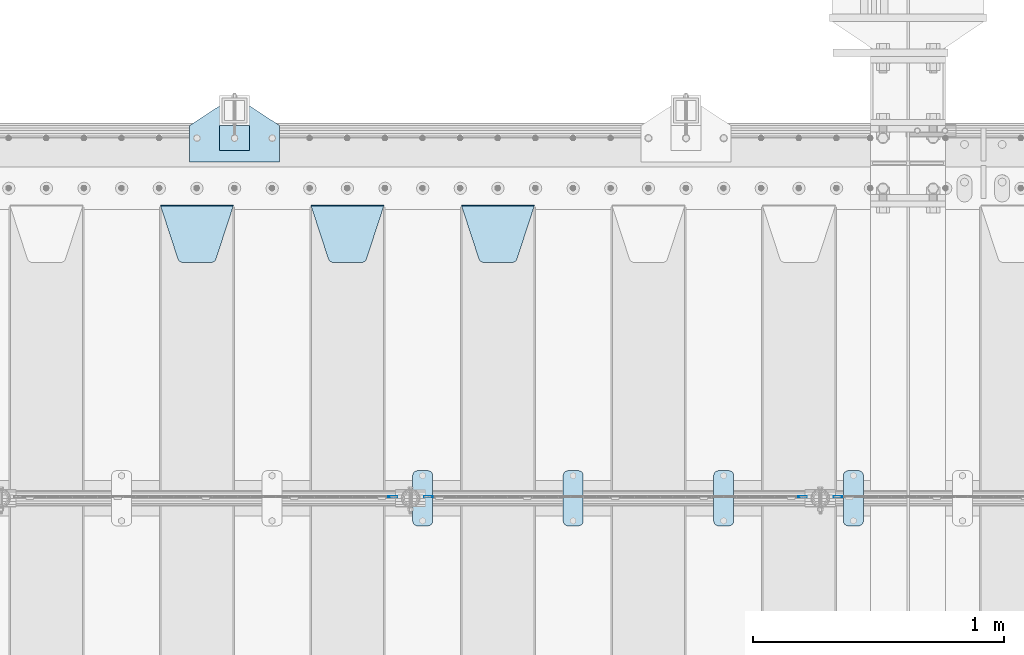
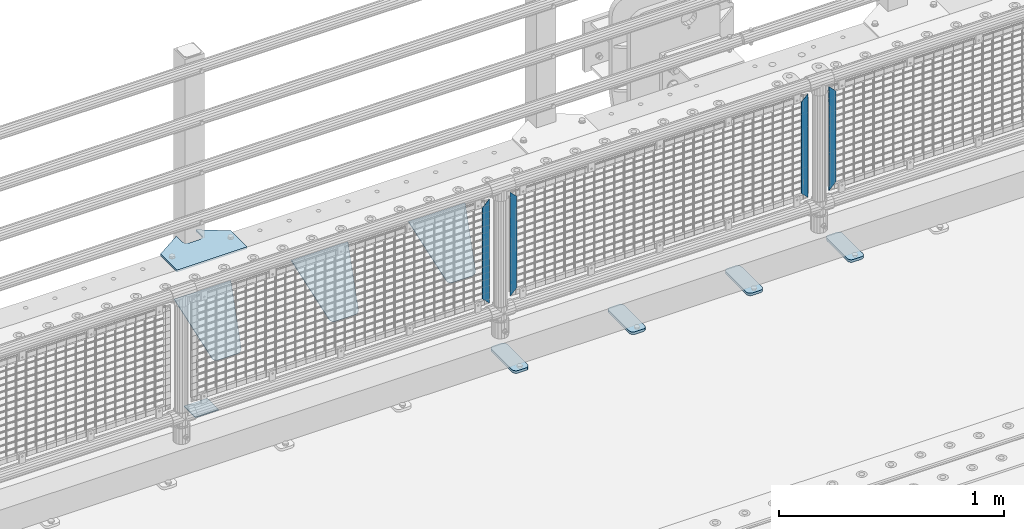
# One storey, part 237 of 270: 13 plates.
"""IFC2X3 building model written with IfcOpenShell, lengths in millimetres."""

from ifc_helpers import new_model, si_unit, frame, origin_with_axes, place, context, subcontext, project, spatial, faceted_brep, material, type_object, element, save


model = new_model("IFC2X3")

# Units and contexts
model_context = context("Model", 3, precision=1e-05, world=origin_with_axes())
body_context = subcontext(model_context, "Body", "Model", "MODEL_VIEW")
ifc_project = project(units=[si_unit("LENGTHUNIT", "METRE", prefix="MILLI"), si_unit("AREAUNIT", "SQUARE_METRE"), si_unit("VOLUMEUNIT", "CUBIC_METRE"), si_unit("MASSUNIT", "GRAM", prefix="KILO"), si_unit("TIMEUNIT", "SECOND"), si_unit("PLANEANGLEUNIT", "RADIAN"), si_unit("SOLIDANGLEUNIT", "STERADIAN"), si_unit("THERMODYNAMICTEMPERATUREUNIT", "DEGREE_CELSIUS"), si_unit("LUMINOUSINTENSITYUNIT", "LUMEN")], contexts=[model_context])

# Site, building, storey
site_placement = place(None, origin_with_axes())
site = spatial("IfcSite", under=ifc_project, at=site_placement, CompositionType="ELEMENT")
building_placement = place(site_placement, origin_with_axes())
building = spatial("IfcBuilding", under=site, at=building_placement, Name="Standard", CompositionType="ELEMENT")
storey_placement = place(building_placement, origin_with_axes())
storey = spatial("IfcBuildingStorey", under=building, at=storey_placement, Name="Undefined", CompositionType="ELEMENT", Elevation=0.0)

# Plates
ifc_material_1 = material(Name="STEEL/S355J2")
plate_type_1 = type_object("IfcPlateType", PredefinedType="NOTDEFINED")
plate_1_placement = place(storey_placement, frame((11170.0, -14995.0, 5.00000000004911), z_axis=(0.0, 1.0, 0.0), x_axis=(1.0, 0.0, 0.0)))
element("IfcPlate", 1, at=plate_1_placement, inside=storey, type_object=plate_type_1, material=ifc_material_1, context=body_context, shape_type="Brep", body=[
    faceted_brep([(0.0, -5.0, 0.0), (2.31396552408114e-06, -5.0, 145.0), (2.31396552408114e-06, 5.0, 145.0), (0.0, 5.0, 0.0), (130.0, -5.0, 230.0), (130.0, 5.0, 230.0), (130.0, -5.0, 180.0), (130.0, 5.0, 180.0), (130.48036798992, -5.0, 175.122741949597), (130.48036798992, 5.0, 175.122741949597), (131.903011687216, -5.0, 170.432914190873), (131.903011687216, 5.0, 170.432914190873), (134.213259692435, -5.0, 166.11074417451), (134.213259692435, 5.0, 166.11074417451), (137.322330470335, -5.0, 162.322330470337), (137.322330470335, 5.0, 162.322330470337), (141.110744174512, -5.0, 159.213259692437), (141.110744174512, 5.0, 159.213259692437), (145.432914190871, -5.0, 156.903011687218), (145.432914190871, 5.0, 156.903011687218), (150.122741949595, -5.0, 155.48036798992), (150.122741949595, 5.0, 155.48036798992), (155.0, -5.0, 155.0), (155.0, 5.0, 155.0), (205.0, -5.0, 155.0), (205.0, 5.0, 155.0), (209.877258050405, -5.0, 155.48036798992), (209.877258050405, 5.0, 155.48036798992), (214.567085809129, -5.0, 156.903011687218), (214.567085809129, 5.0, 156.903011687218), (218.889255825488, -5.0, 159.213259692437), (218.889255825488, 5.0, 159.213259692437), (222.677669529665, -5.0, 162.322330470337), (222.677669529665, 5.0, 162.322330470337), (225.786740307565, -5.0, 166.11074417451), (225.786740307565, 5.0, 166.11074417451), (228.096988312784, -5.0, 170.432914190873), (228.096988312784, 5.0, 170.432914190873), (229.51963201008, -5.0, 175.122741949597), (229.51963201008, 5.0, 175.122741949597), (230.0, -5.0, 180.0), (230.0, 5.0, 180.0), (230.0, -5.0, 230.0), (230.0, 5.0, 230.0), (360.0, -5.0, 145.0), (360.0, 5.0, 145.0), (360.0, -5.0, -7.27595761418343e-12), (360.0, 5.0, -7.27595761418343e-12)], [[[0, 1, 2, 3]], [[1, 4, 5, 2]], [[4, 6, 7, 5]], [[6, 8, 9, 7]], [[8, 10, 11, 9]], [[10, 12, 13, 11]], [[12, 14, 15, 13]], [[14, 16, 17, 15]], [[16, 18, 19, 17]], [[18, 20, 21, 19]], [[20, 22, 23, 21]], [[22, 24, 25, 23]], [[24, 26, 27, 25]], [[26, 28, 29, 27]], [[28, 30, 31, 29]], [[30, 32, 33, 31]], [[32, 34, 35, 33]], [[34, 36, 37, 35]], [[36, 38, 39, 37]], [[38, 40, 41, 39]], [[40, 42, 43, 41]], [[42, 44, 45, 43]], [[44, 46, 47, 45]], [[46, 0, 3, 47]], [[5, 7, 9, 11, 13, 15, 17, 19, 21, 23, 25, 27, 29, 31, 33, 35, 37, 39, 41, 43, 45, 47, 3, 2]], [[46, 44, 42, 40, 38, 36, 34, 32, 30, 28, 26, 24, 22, 20, 18, 16, 14, 12, 10, 8, 6, 4, 1, 0]]]),
])
plate_type_2 = type_object("IfcPlateType", PredefinedType="NOTDEFINED")
plate_2_placement = place(storey_placement, frame((11290.0000000001, -14949.9999999998, -857.500000000002), z_axis=(0.0, 1.0, 0.0), x_axis=(1.0, 0.0, 0.0)))
element("IfcPlate", 2, at=plate_2_placement, inside=storey, type_object=plate_type_2, material=ifc_material_1, context=body_context, shape_type="Brep", body=[
    faceted_brep([(0.0, -2.5, 0.0), (0.0, -2.5, 100.0), (0.0, 2.5, 100.0), (0.0, 2.5, 0.0), (120.0, -2.5, 100.0), (120.0, 2.5, 100.0), (120.0, -2.5, 0.0), (120.0, 2.5, 0.0)], [[[0, 1, 2, 3]], [[1, 4, 5, 2]], [[4, 6, 7, 5]], [[6, 0, 3, 7]], [[5, 7, 3, 2]], [[6, 4, 1, 0]]]),
])
plate_type_3 = type_object("IfcPlateType", PredefinedType="NOTDEFINED")
plate_3_placement = place(storey_placement, frame((13777.0, -16225.5, 21.0199999999977), z_axis=(1.0, 0.0, 0.0), x_axis=(0.0, -1.0, 0.0)))
element("IfcPlate", 3, at=plate_3_placement, inside=storey, type_object=plate_type_3, material=ifc_material_1, context=body_context, shape_type="Brep", body=[
    faceted_brep([(0.0, -7.0, 20.0), (0.0, -7.0, 60.0), (0.0, 7.0, 60.0), (0.0, 7.0, 20.0), (0.384294391937146, -7.0, 63.9018064403208), (0.384294391937146, 7.0, 63.9018064403208), (1.52240934977453, -7.0, 67.6536686473009), (1.52240934977453, 7.0, 67.6536686473009), (3.37060775395003, -7.0, 71.1114046603907), (3.37060775395003, 7.0, 71.1114046603907), (5.8578643762703, -7.0, 74.1421356237297), (5.8578643762703, 7.0, 74.1421356237297), (8.88859533960931, -7.0, 76.62939224605), (8.88859533960931, 7.0, 76.62939224605), (12.3463313526991, -7.0, 78.4775906502255), (12.3463313526991, 7.0, 78.4775906502255), (16.0981935596792, -7.0, 79.6157056080629), (16.0981935596792, 7.0, 79.6157056080629), (20.0, -7.0, 80.0), (20.0, 7.0, 80.0), (200.0, -7.0, 80.0), (200.0, 7.0, 80.0), (203.901806440321, -7.0, 79.6157056080629), (203.901806440321, 7.0, 79.6157056080629), (207.653668647301, -7.0, 78.4775906502255), (207.653668647301, 7.0, 78.4775906502255), (211.111404660391, -7.0, 76.62939224605), (211.111404660391, 7.0, 76.62939224605), (214.142135623733, -7.0, 74.1421356237297), (214.142135623733, 7.0, 74.1421356237297), (216.629392246054, -7.0, 71.1114046603907), (216.629392246054, 7.0, 71.1114046603907), (218.477590650225, -7.0, 67.6536686473009), (218.477590650225, 7.0, 67.6536686473009), (219.615705608063, -7.0, 63.9018064403208), (219.615705608063, 7.0, 63.9018064403208), (220.0, -7.0, 60.0), (220.0, 7.0, 60.0), (220.0, -7.0, 20.0), (220.0, 7.0, 20.0), (219.615705608063, -7.0, 16.0981935596792), (219.615705608063, 7.0, 16.0981935596792), (218.477590650225, -7.0, 12.3463313526991), (218.477590650225, 7.0, 12.3463313526991), (216.629392246054, -7.0, 8.88859533960931), (216.629392246054, 7.0, 8.88859533960931), (214.142135623733, -7.0, 5.8578643762703), (214.142135623733, 7.0, 5.8578643762703), (211.111404660391, -7.0, 3.37060775395003), (211.111404660391, 7.0, 3.37060775395003), (207.653668647301, -7.0, 1.52240934977453), (207.653668647301, 7.0, 1.52240934977453), (203.901806440321, -7.0, 0.384294391937146), (203.901806440321, 7.0, 0.384294391937146), (200.0, -7.0, 0.0), (200.0, 7.0, 0.0), (20.0, -7.0, 0.0), (20.0, 7.0, 0.0), (16.0981935596792, -7.0, 0.384294391937146), (16.0981935596792, 7.0, 0.384294391937146), (12.3463313526991, -7.0, 1.52240934977453), (12.3463313526991, 7.0, 1.52240934977453), (8.88859533960931, -7.0, 3.37060775395003), (8.88859533960931, 7.0, 3.37060775395003), (5.8578643762703, -7.0, 5.8578643762703), (5.8578643762703, 7.0, 5.8578643762703), (3.37060775395003, -7.0, 8.88859533960931), (3.37060775395003, 7.0, 8.88859533960931), (1.52240934977453, -7.0, 12.3463313526991), (1.52240934977453, 7.0, 12.3463313526991), (0.384294391937146, -7.0, 16.0981935596792), (0.384294391937146, 7.0, 16.0981935596792)], [[[0, 1, 2, 3]], [[1, 4, 5, 2]], [[4, 6, 7, 5]], [[6, 8, 9, 7]], [[8, 10, 11, 9]], [[10, 12, 13, 11]], [[12, 14, 15, 13]], [[14, 16, 17, 15]], [[16, 18, 19, 17]], [[18, 20, 21, 19]], [[20, 22, 23, 21]], [[22, 24, 25, 23]], [[24, 26, 27, 25]], [[26, 28, 29, 27]], [[28, 30, 31, 29]], [[30, 32, 33, 31]], [[32, 34, 35, 33]], [[34, 36, 37, 35]], [[36, 38, 39, 37]], [[38, 40, 41, 39]], [[40, 42, 43, 41]], [[42, 44, 45, 43]], [[44, 46, 47, 45]], [[46, 48, 49, 47]], [[48, 50, 51, 49]], [[50, 52, 53, 51]], [[52, 54, 55, 53]], [[54, 56, 57, 55]], [[56, 58, 59, 57]], [[58, 60, 61, 59]], [[60, 62, 63, 61]], [[62, 64, 65, 63]], [[64, 66, 67, 65]], [[66, 68, 69, 67]], [[68, 70, 71, 69]], [[70, 0, 3, 71]], [[5, 7, 9, 11, 13, 15, 17, 19, 21, 23, 25, 27, 29, 31, 33, 35, 37, 39, 41, 43, 45, 47, 49, 51, 53, 55, 57, 59, 61, 63, 65, 67, 69, 71, 3, 2]], [[70, 68, 66, 64, 62, 60, 58, 56, 54, 52, 50, 48, 46, 44, 42, 40, 38, 36, 34, 32, 30, 28, 26, 24, 22, 20, 18, 16, 14, 12, 10, 8, 6, 4, 1, 0]]]),
])
plate_4_placement = place(storey_placement, frame((13260.0, -16225.5, 21.0199999999977), z_axis=(1.0, 0.0, 0.0), x_axis=(0.0, -1.0, 0.0)))
element("IfcPlate", 4, at=plate_4_placement, inside=storey, type_object=plate_type_3, material=ifc_material_1, context=body_context, shape_type="Brep", body=[
    faceted_brep([(0.0, -7.0, 20.0), (0.0, -7.0, 60.0), (0.0, 7.0, 60.0), (0.0, 7.0, 20.0), (0.384294391937146, -7.0, 63.9018064403208), (0.384294391937146, 7.0, 63.9018064403208), (1.52240934977453, -7.0, 67.6536686473009), (1.52240934977453, 7.0, 67.6536686473009), (3.37060775395003, -7.0, 71.1114046603907), (3.37060775395003, 7.0, 71.1114046603907), (5.8578643762703, -7.0, 74.1421356237297), (5.8578643762703, 7.0, 74.1421356237297), (8.88859533960931, -7.0, 76.62939224605), (8.88859533960931, 7.0, 76.62939224605), (12.3463313526991, -7.0, 78.4775906502255), (12.3463313526991, 7.0, 78.4775906502255), (16.0981935596792, -7.0, 79.6157056080629), (16.0981935596792, 7.0, 79.6157056080629), (20.0, -7.0, 80.0), (20.0, 7.0, 80.0), (200.0, -7.0, 80.0), (200.0, 7.0, 80.0), (203.901806440321, -7.0, 79.6157056080629), (203.901806440321, 7.0, 79.6157056080629), (207.653668647301, -7.0, 78.4775906502255), (207.653668647301, 7.0, 78.4775906502255), (211.111404660391, -7.0, 76.62939224605), (211.111404660391, 7.0, 76.62939224605), (214.142135623733, -7.0, 74.1421356237297), (214.142135623733, 7.0, 74.1421356237297), (216.629392246054, -7.0, 71.1114046603907), (216.629392246054, 7.0, 71.1114046603907), (218.477590650225, -7.0, 67.6536686473009), (218.477590650225, 7.0, 67.6536686473009), (219.615705608063, -7.0, 63.9018064403208), (219.615705608063, 7.0, 63.9018064403208), (220.0, -7.0, 60.0), (220.0, 7.0, 60.0), (220.0, -7.0, 20.0), (220.0, 7.0, 20.0), (219.615705608063, -7.0, 16.0981935596792), (219.615705608063, 7.0, 16.0981935596792), (218.477590650225, -7.0, 12.3463313526991), (218.477590650225, 7.0, 12.3463313526991), (216.629392246054, -7.0, 8.88859533960931), (216.629392246054, 7.0, 8.88859533960931), (214.142135623733, -7.0, 5.8578643762703), (214.142135623733, 7.0, 5.8578643762703), (211.111404660391, -7.0, 3.37060775395003), (211.111404660391, 7.0, 3.37060775395003), (207.653668647301, -7.0, 1.52240934977453), (207.653668647301, 7.0, 1.52240934977453), (203.901806440321, -7.0, 0.384294391937146), (203.901806440321, 7.0, 0.384294391937146), (200.0, -7.0, 0.0), (200.0, 7.0, 0.0), (20.0, -7.0, 0.0), (20.0, 7.0, 0.0), (16.0981935596792, -7.0, 0.384294391937146), (16.0981935596792, 7.0, 0.384294391937146), (12.3463313526991, -7.0, 1.52240934977453), (12.3463313526991, 7.0, 1.52240934977453), (8.88859533960931, -7.0, 3.37060775395003), (8.88859533960931, 7.0, 3.37060775395003), (5.8578643762703, -7.0, 5.8578643762703), (5.8578643762703, 7.0, 5.8578643762703), (3.37060775395003, -7.0, 8.88859533960931), (3.37060775395003, 7.0, 8.88859533960931), (1.52240934977453, -7.0, 12.3463313526991), (1.52240934977453, 7.0, 12.3463313526991), (0.384294391937146, -7.0, 16.0981935596792), (0.384294391937146, 7.0, 16.0981935596792)], [[[0, 1, 2, 3]], [[1, 4, 5, 2]], [[4, 6, 7, 5]], [[6, 8, 9, 7]], [[8, 10, 11, 9]], [[10, 12, 13, 11]], [[12, 14, 15, 13]], [[14, 16, 17, 15]], [[16, 18, 19, 17]], [[18, 20, 21, 19]], [[20, 22, 23, 21]], [[22, 24, 25, 23]], [[24, 26, 27, 25]], [[26, 28, 29, 27]], [[28, 30, 31, 29]], [[30, 32, 33, 31]], [[32, 34, 35, 33]], [[34, 36, 37, 35]], [[36, 38, 39, 37]], [[38, 40, 41, 39]], [[40, 42, 43, 41]], [[42, 44, 45, 43]], [[44, 46, 47, 45]], [[46, 48, 49, 47]], [[48, 50, 51, 49]], [[50, 52, 53, 51]], [[52, 54, 55, 53]], [[54, 56, 57, 55]], [[56, 58, 59, 57]], [[58, 60, 61, 59]], [[60, 62, 63, 61]], [[62, 64, 65, 63]], [[64, 66, 67, 65]], [[66, 68, 69, 67]], [[68, 70, 71, 69]], [[70, 0, 3, 71]], [[5, 7, 9, 11, 13, 15, 17, 19, 21, 23, 25, 27, 29, 31, 33, 35, 37, 39, 41, 43, 45, 47, 49, 51, 53, 55, 57, 59, 61, 63, 65, 67, 69, 71, 3, 2]], [[70, 68, 66, 64, 62, 60, 58, 56, 54, 52, 50, 48, 46, 44, 42, 40, 38, 36, 34, 32, 30, 28, 26, 24, 22, 20, 18, 16, 14, 12, 10, 8, 6, 4, 1, 0]]]),
])
plate_5_placement = place(storey_placement, frame((12660.0, -16225.5, 21.0199999999977), z_axis=(1.0, 0.0, 0.0), x_axis=(0.0, -1.0, 0.0)))
element("IfcPlate", 5, at=plate_5_placement, inside=storey, type_object=plate_type_3, material=ifc_material_1, context=body_context, shape_type="Brep", body=[
    faceted_brep([(0.0, -7.0, 20.0), (0.0, -7.0, 60.0), (0.0, 7.0, 60.0), (0.0, 7.0, 20.0), (0.384294391937146, -7.0, 63.9018064403208), (0.384294391937146, 7.0, 63.9018064403208), (1.52240934977453, -7.0, 67.6536686473009), (1.52240934977453, 7.0, 67.6536686473009), (3.37060775395003, -7.0, 71.1114046603907), (3.37060775395003, 7.0, 71.1114046603907), (5.8578643762703, -7.0, 74.1421356237297), (5.8578643762703, 7.0, 74.1421356237297), (8.88859533960931, -7.0, 76.62939224605), (8.88859533960931, 7.0, 76.62939224605), (12.3463313526991, -7.0, 78.4775906502255), (12.3463313526991, 7.0, 78.4775906502255), (16.0981935596792, -7.0, 79.6157056080629), (16.0981935596792, 7.0, 79.6157056080629), (20.0, -7.0, 80.0), (20.0, 7.0, 80.0), (200.0, -7.0, 80.0), (200.0, 7.0, 80.0), (203.901806440321, -7.0, 79.6157056080629), (203.901806440321, 7.0, 79.6157056080629), (207.653668647301, -7.0, 78.4775906502255), (207.653668647301, 7.0, 78.4775906502255), (211.111404660391, -7.0, 76.62939224605), (211.111404660391, 7.0, 76.62939224605), (214.142135623733, -7.0, 74.1421356237297), (214.142135623733, 7.0, 74.1421356237297), (216.629392246054, -7.0, 71.1114046603907), (216.629392246054, 7.0, 71.1114046603907), (218.477590650225, -7.0, 67.6536686473009), (218.477590650225, 7.0, 67.6536686473009), (219.615705608063, -7.0, 63.9018064403208), (219.615705608063, 7.0, 63.9018064403208), (220.0, -7.0, 60.0), (220.0, 7.0, 60.0), (220.0, -7.0, 20.0), (220.0, 7.0, 20.0), (219.615705608063, -7.0, 16.0981935596792), (219.615705608063, 7.0, 16.0981935596792), (218.477590650225, -7.0, 12.3463313526991), (218.477590650225, 7.0, 12.3463313526991), (216.629392246054, -7.0, 8.88859533960931), (216.629392246054, 7.0, 8.88859533960931), (214.142135623733, -7.0, 5.8578643762703), (214.142135623733, 7.0, 5.8578643762703), (211.111404660391, -7.0, 3.37060775395003), (211.111404660391, 7.0, 3.37060775395003), (207.653668647301, -7.0, 1.52240934977453), (207.653668647301, 7.0, 1.52240934977453), (203.901806440321, -7.0, 0.384294391937146), (203.901806440321, 7.0, 0.384294391937146), (200.0, -7.0, 0.0), (200.0, 7.0, 0.0), (20.0, -7.0, 0.0), (20.0, 7.0, 0.0), (16.0981935596792, -7.0, 0.384294391937146), (16.0981935596792, 7.0, 0.384294391937146), (12.3463313526991, -7.0, 1.52240934977453), (12.3463313526991, 7.0, 1.52240934977453), (8.88859533960931, -7.0, 3.37060775395003), (8.88859533960931, 7.0, 3.37060775395003), (5.8578643762703, -7.0, 5.8578643762703), (5.8578643762703, 7.0, 5.8578643762703), (3.37060775395003, -7.0, 8.88859533960931), (3.37060775395003, 7.0, 8.88859533960931), (1.52240934977453, -7.0, 12.3463313526991), (1.52240934977453, 7.0, 12.3463313526991), (0.384294391937146, -7.0, 16.0981935596792), (0.384294391937146, 7.0, 16.0981935596792)], [[[0, 1, 2, 3]], [[1, 4, 5, 2]], [[4, 6, 7, 5]], [[6, 8, 9, 7]], [[8, 10, 11, 9]], [[10, 12, 13, 11]], [[12, 14, 15, 13]], [[14, 16, 17, 15]], [[16, 18, 19, 17]], [[18, 20, 21, 19]], [[20, 22, 23, 21]], [[22, 24, 25, 23]], [[24, 26, 27, 25]], [[26, 28, 29, 27]], [[28, 30, 31, 29]], [[30, 32, 33, 31]], [[32, 34, 35, 33]], [[34, 36, 37, 35]], [[36, 38, 39, 37]], [[38, 40, 41, 39]], [[40, 42, 43, 41]], [[42, 44, 45, 43]], [[44, 46, 47, 45]], [[46, 48, 49, 47]], [[48, 50, 51, 49]], [[50, 52, 53, 51]], [[52, 54, 55, 53]], [[54, 56, 57, 55]], [[56, 58, 59, 57]], [[58, 60, 61, 59]], [[60, 62, 63, 61]], [[62, 64, 65, 63]], [[64, 66, 67, 65]], [[66, 68, 69, 67]], [[68, 70, 71, 69]], [[70, 0, 3, 71]], [[5, 7, 9, 11, 13, 15, 17, 19, 21, 23, 25, 27, 29, 31, 33, 35, 37, 39, 41, 43, 45, 47, 49, 51, 53, 55, 57, 59, 61, 63, 65, 67, 69, 71, 3, 2]], [[70, 68, 66, 64, 62, 60, 58, 56, 54, 52, 50, 48, 46, 44, 42, 40, 38, 36, 34, 32, 30, 28, 26, 24, 22, 20, 18, 16, 14, 12, 10, 8, 6, 4, 1, 0]]]),
])
plate_6_placement = place(storey_placement, frame((12060.0, -16225.5, 21.0199999999977), z_axis=(1.0, 0.0, 0.0), x_axis=(0.0, -1.0, 0.0)))
element("IfcPlate", 6, at=plate_6_placement, inside=storey, type_object=plate_type_3, material=ifc_material_1, context=body_context, shape_type="Brep", body=[
    faceted_brep([(0.0, -7.0, 20.0), (0.0, -7.0, 60.0), (0.0, 7.0, 60.0), (0.0, 7.0, 20.0), (0.384294391937146, -7.0, 63.9018064403208), (0.384294391937146, 7.0, 63.9018064403208), (1.52240934977453, -7.0, 67.6536686473009), (1.52240934977453, 7.0, 67.6536686473009), (3.37060775395003, -7.0, 71.1114046603907), (3.37060775395003, 7.0, 71.1114046603907), (5.8578643762703, -7.0, 74.1421356237297), (5.8578643762703, 7.0, 74.1421356237297), (8.88859533960931, -7.0, 76.62939224605), (8.88859533960931, 7.0, 76.62939224605), (12.3463313526991, -7.0, 78.4775906502255), (12.3463313526991, 7.0, 78.4775906502255), (16.0981935596792, -7.0, 79.6157056080629), (16.0981935596792, 7.0, 79.6157056080629), (20.0, -7.0, 80.0), (20.0, 7.0, 80.0), (200.0, -7.0, 80.0), (200.0, 7.0, 80.0), (203.901806440321, -7.0, 79.6157056080629), (203.901806440321, 7.0, 79.6157056080629), (207.653668647301, -7.0, 78.4775906502255), (207.653668647301, 7.0, 78.4775906502255), (211.111404660391, -7.0, 76.62939224605), (211.111404660391, 7.0, 76.62939224605), (214.142135623733, -7.0, 74.1421356237297), (214.142135623733, 7.0, 74.1421356237297), (216.629392246054, -7.0, 71.1114046603907), (216.629392246054, 7.0, 71.1114046603907), (218.477590650225, -7.0, 67.6536686473009), (218.477590650225, 7.0, 67.6536686473009), (219.615705608063, -7.0, 63.9018064403208), (219.615705608063, 7.0, 63.9018064403208), (220.0, -7.0, 60.0), (220.0, 7.0, 60.0), (220.0, -7.0, 20.0), (220.0, 7.0, 20.0), (219.615705608063, -7.0, 16.0981935596792), (219.615705608063, 7.0, 16.0981935596792), (218.477590650225, -7.0, 12.3463313526991), (218.477590650225, 7.0, 12.3463313526991), (216.629392246054, -7.0, 8.88859533960931), (216.629392246054, 7.0, 8.88859533960931), (214.142135623733, -7.0, 5.8578643762703), (214.142135623733, 7.0, 5.8578643762703), (211.111404660391, -7.0, 3.37060775395003), (211.111404660391, 7.0, 3.37060775395003), (207.653668647301, -7.0, 1.52240934977453), (207.653668647301, 7.0, 1.52240934977453), (203.901806440321, -7.0, 0.384294391937146), (203.901806440321, 7.0, 0.384294391937146), (200.0, -7.0, 0.0), (200.0, 7.0, 0.0), (20.0, -7.0, 0.0), (20.0, 7.0, 0.0), (16.0981935596792, -7.0, 0.384294391937146), (16.0981935596792, 7.0, 0.384294391937146), (12.3463313526991, -7.0, 1.52240934977453), (12.3463313526991, 7.0, 1.52240934977453), (8.88859533960931, -7.0, 3.37060775395003), (8.88859533960931, 7.0, 3.37060775395003), (5.8578643762703, -7.0, 5.8578643762703), (5.8578643762703, 7.0, 5.8578643762703), (3.37060775395003, -7.0, 8.88859533960931), (3.37060775395003, 7.0, 8.88859533960931), (1.52240934977453, -7.0, 12.3463313526991), (1.52240934977453, 7.0, 12.3463313526991), (0.384294391937146, -7.0, 16.0981935596792), (0.384294391937146, 7.0, 16.0981935596792)], [[[0, 1, 2, 3]], [[1, 4, 5, 2]], [[4, 6, 7, 5]], [[6, 8, 9, 7]], [[8, 10, 11, 9]], [[10, 12, 13, 11]], [[12, 14, 15, 13]], [[14, 16, 17, 15]], [[16, 18, 19, 17]], [[18, 20, 21, 19]], [[20, 22, 23, 21]], [[22, 24, 25, 23]], [[24, 26, 27, 25]], [[26, 28, 29, 27]], [[28, 30, 31, 29]], [[30, 32, 33, 31]], [[32, 34, 35, 33]], [[34, 36, 37, 35]], [[36, 38, 39, 37]], [[38, 40, 41, 39]], [[40, 42, 43, 41]], [[42, 44, 45, 43]], [[44, 46, 47, 45]], [[46, 48, 49, 47]], [[48, 50, 51, 49]], [[50, 52, 53, 51]], [[52, 54, 55, 53]], [[54, 56, 57, 55]], [[56, 58, 59, 57]], [[58, 60, 61, 59]], [[60, 62, 63, 61]], [[62, 64, 65, 63]], [[64, 66, 67, 65]], [[66, 68, 69, 67]], [[68, 70, 71, 69]], [[70, 0, 3, 71]], [[5, 7, 9, 11, 13, 15, 17, 19, 21, 23, 25, 27, 29, 31, 33, 35, 37, 39, 41, 43, 45, 47, 49, 51, 53, 55, 57, 59, 61, 63, 65, 67, 69, 71, 3, 2]], [[70, 68, 66, 64, 62, 60, 58, 56, 54, 52, 50, 48, 46, 44, 42, 40, 38, 36, 34, 32, 30, 28, 26, 24, 22, 20, 18, 16, 14, 12, 10, 8, 6, 4, 1, 0]]]),
])
ifc_material_2 = material(Name="STEEL/S355N")
plate_type_4 = type_object("IfcPlateType", PredefinedType="NOTDEFINED")
plate_7_placement = place(storey_placement, frame((12255.0, -15168.2322330441, -1.76776695296576), z_axis=(0.0, -0.707106781186548, -0.707106781186547), x_axis=(1.0, 0.0, 0.0)))
element("IfcPlate", 7, at=plate_7_placement, inside=storey, type_object=plate_type_4, material=ifc_material_2, context=body_context, shape_type="Brep", body=[
    faceted_brep([(0.0, -2.5, 0.0), (69.345504679477, -2.5, 300.171731424831), (69.345504679477, 2.5, 300.171731424831), (0.0, 2.5, 0.0), (70.9274061199576, -2.5, 304.8974424154), (70.9274061199576, 2.5, 304.8974424154), (73.3818627772307, -2.49999999999818, 309.234538108527), (73.3818627772307, 2.50000000000182, 309.234538108527), (76.6187032999551, -2.5, 313.023683126103), (76.6187032999551, 2.5, 313.023683126103), (80.5190132704993, -2.5, 316.125672595372), (80.5190132704993, 2.50000000000182, 316.125672595372), (84.9395038596849, -2.49999999999818, 318.426546230476), (84.9395038596849, 2.5, 318.426546230476), (89.7177759439219, -2.49999999999818, 319.841774983275), (89.7177759439219, 2.50000000000182, 319.841774983275), (94.678286292652, -2.5, 320.319366455078), (94.678286292652, 2.5, 320.319366455078), (195.321713707348, -2.5, 320.319366455078), (195.321713707348, 2.5, 320.319366455078), (200.282224056078, -2.49999999999818, 319.841774983275), (200.282224056078, 2.50000000000182, 319.841774983275), (205.060496140315, -2.5, 318.426546230476), (205.060496140315, 2.5, 318.426546230476), (209.480986729501, -2.5, 316.12567259537), (209.480986729501, 2.50000000000182, 316.12567259537), (213.381296700045, -2.5, 313.023683126103), (213.381296700045, 2.5, 313.023683126103), (216.618137222769, -2.49999999999818, 309.234538108525), (216.618137222769, 2.50000000000182, 309.234538108527), (219.072593880042, -2.49999999999818, 304.897442415398), (219.072593880042, 2.50000000000182, 304.897442415397), (220.654495320523, -2.5, 300.171731424831), (220.654495320523, 2.5, 300.171731424831), (290.0, -2.49999999999818, 0.0), (290.0, 2.5, 0.0)], [[[0, 1, 2, 3]], [[1, 4, 5, 2]], [[4, 6, 7, 5]], [[6, 8, 9, 7]], [[8, 10, 11, 9]], [[10, 12, 13, 11]], [[12, 14, 15, 13]], [[14, 16, 17, 15]], [[16, 18, 19, 17]], [[18, 20, 21, 19]], [[20, 22, 23, 21]], [[22, 24, 25, 23]], [[24, 26, 27, 25]], [[26, 28, 29, 27]], [[28, 30, 31, 29]], [[30, 32, 33, 31]], [[32, 34, 35, 33]], [[34, 0, 3, 35]], [[5, 7, 9, 11, 13, 15, 17, 19, 21, 23, 25, 27, 29, 31, 33, 35, 3, 2]], [[34, 32, 30, 28, 26, 24, 22, 20, 18, 16, 14, 12, 10, 8, 6, 4, 1, 0]]]),
])
plate_8_placement = place(storey_placement, frame((11655.0, -15168.2322330441, -1.76776695296576), z_axis=(0.0, -0.707106781186548, -0.707106781186547), x_axis=(1.0, 0.0, 0.0)))
element("IfcPlate", 8, at=plate_8_placement, inside=storey, type_object=plate_type_4, material=ifc_material_2, context=body_context, shape_type="Brep", body=[
    faceted_brep([(0.0, -2.5, 0.0), (69.345504679477, -2.5, 300.171731424831), (69.345504679477, 2.5, 300.171731424831), (0.0, 2.5, 0.0), (70.9274061199576, -2.5, 304.8974424154), (70.9274061199576, 2.5, 304.8974424154), (73.3818627772307, -2.49999999999818, 309.234538108527), (73.3818627772307, 2.50000000000182, 309.234538108527), (76.6187032999551, -2.5, 313.023683126103), (76.6187032999551, 2.5, 313.023683126103), (80.5190132704993, -2.5, 316.125672595372), (80.5190132704993, 2.50000000000182, 316.125672595372), (84.9395038596849, -2.49999999999818, 318.426546230476), (84.9395038596849, 2.5, 318.426546230476), (89.7177759439219, -2.49999999999818, 319.841774983275), (89.7177759439219, 2.50000000000182, 319.841774983275), (94.678286292652, -2.5, 320.319366455078), (94.678286292652, 2.5, 320.319366455078), (195.321713707348, -2.5, 320.319366455078), (195.321713707348, 2.5, 320.319366455078), (200.282224056078, -2.49999999999818, 319.841774983275), (200.282224056078, 2.50000000000182, 319.841774983275), (205.060496140315, -2.5, 318.426546230476), (205.060496140315, 2.5, 318.426546230476), (209.480986729501, -2.5, 316.12567259537), (209.480986729501, 2.50000000000182, 316.12567259537), (213.381296700045, -2.5, 313.023683126103), (213.381296700045, 2.5, 313.023683126103), (216.618137222769, -2.49999999999818, 309.234538108525), (216.618137222769, 2.50000000000182, 309.234538108527), (219.072593880042, -2.49999999999818, 304.897442415398), (219.072593880042, 2.50000000000182, 304.897442415397), (220.654495320523, -2.5, 300.171731424831), (220.654495320523, 2.5, 300.171731424831), (290.0, -2.49999999999818, 0.0), (290.0, 2.5, 0.0)], [[[0, 1, 2, 3]], [[1, 4, 5, 2]], [[4, 6, 7, 5]], [[6, 8, 9, 7]], [[8, 10, 11, 9]], [[10, 12, 13, 11]], [[12, 14, 15, 13]], [[14, 16, 17, 15]], [[16, 18, 19, 17]], [[18, 20, 21, 19]], [[20, 22, 23, 21]], [[22, 24, 25, 23]], [[24, 26, 27, 25]], [[26, 28, 29, 27]], [[28, 30, 31, 29]], [[30, 32, 33, 31]], [[32, 34, 35, 33]], [[34, 0, 3, 35]], [[5, 7, 9, 11, 13, 15, 17, 19, 21, 23, 25, 27, 29, 31, 33, 35, 3, 2]], [[34, 32, 30, 28, 26, 24, 22, 20, 18, 16, 14, 12, 10, 8, 6, 4, 1, 0]]]),
])
plate_9_placement = place(storey_placement, frame((11055.0, -15168.2322330441, -1.76776695296576), z_axis=(0.0, -0.707106781186548, -0.707106781186547), x_axis=(1.0, 0.0, 0.0)))
element("IfcPlate", 9, at=plate_9_placement, inside=storey, type_object=plate_type_4, material=ifc_material_2, context=body_context, shape_type="Brep", body=[
    faceted_brep([(0.0, -2.5, 0.0), (69.345504679477, -2.5, 300.171731424831), (69.345504679477, 2.5, 300.171731424831), (0.0, 2.5, 0.0), (70.9274061199576, -2.5, 304.8974424154), (70.9274061199576, 2.5, 304.8974424154), (73.3818627772307, -2.49999999999818, 309.234538108527), (73.3818627772307, 2.50000000000182, 309.234538108527), (76.6187032999551, -2.5, 313.023683126103), (76.6187032999551, 2.5, 313.023683126103), (80.5190132704993, -2.5, 316.125672595372), (80.5190132704993, 2.50000000000182, 316.125672595372), (84.9395038596849, -2.49999999999818, 318.426546230476), (84.9395038596849, 2.5, 318.426546230476), (89.7177759439219, -2.49999999999818, 319.841774983275), (89.7177759439219, 2.50000000000182, 319.841774983275), (94.678286292652, -2.5, 320.319366455078), (94.678286292652, 2.5, 320.319366455078), (195.321713707348, -2.5, 320.319366455078), (195.321713707348, 2.5, 320.319366455078), (200.282224056078, -2.49999999999818, 319.841774983275), (200.282224056078, 2.50000000000182, 319.841774983275), (205.060496140315, -2.5, 318.426546230476), (205.060496140315, 2.5, 318.426546230476), (209.480986729501, -2.5, 316.12567259537), (209.480986729501, 2.50000000000182, 316.12567259537), (213.381296700045, -2.5, 313.023683126103), (213.381296700045, 2.5, 313.023683126103), (216.618137222769, -2.49999999999818, 309.234538108525), (216.618137222769, 2.50000000000182, 309.234538108527), (219.072593880042, -2.49999999999818, 304.897442415398), (219.072593880042, 2.50000000000182, 304.897442415397), (220.654495320523, -2.5, 300.171731424831), (220.654495320523, 2.5, 300.171731424831), (290.0, -2.49999999999818, 0.0), (290.0, 2.5, 0.0)], [[[0, 1, 2, 3]], [[1, 4, 5, 2]], [[4, 6, 7, 5]], [[6, 8, 9, 7]], [[8, 10, 11, 9]], [[10, 12, 13, 11]], [[12, 14, 15, 13]], [[14, 16, 17, 15]], [[16, 18, 19, 17]], [[18, 20, 21, 19]], [[20, 22, 23, 21]], [[22, 24, 25, 23]], [[24, 26, 27, 25]], [[26, 28, 29, 27]], [[28, 30, 31, 29]], [[30, 32, 33, 31]], [[32, 34, 35, 33]], [[34, 0, 3, 35]], [[5, 7, 9, 11, 13, 15, 17, 19, 21, 23, 25, 27, 29, 31, 33, 35, 3, 2]], [[34, 32, 30, 28, 26, 24, 22, 20, 18, 16, 14, 12, 10, 8, 6, 4, 1, 0]]]),
])
ifc_material_3 = material(Name="Misc_Undefined")
plate_type_5 = type_object("IfcPlateType", PredefinedType="NOTDEFINED")
for number, where, z_axis, x_axis in (
    (10, (13773.509713541, -16329.5, 879.519963133601), (-0.707008801899319, 0.0, -0.707204746899291), (-0.707204746899302, 0.0, 0.707008801899308)),
    (11, (12140.509713541, -16329.5, 879.519963133601), (-0.707008801899319, 0.0, -0.707204746899291), (-0.707204746899302, 0.0, 0.707008801899308)),
):
    element("IfcPlate", number, at=place(storey_placement, frame(where, z_axis=z_axis, x_axis=x_axis)), inside=storey, type_object=plate_type_5, material=ifc_material_3, context=body_context, shape_type="Brep", body=[
        faceted_brep([(0.0, -1.5, 0.0), (-348.552185058599, -1.5, 348.655029296877), (-348.552185058599, 1.5, 348.655029296877), (0.0, 1.5, 0.0), (-348.544891357427, -1.5, 398.152496337894), (-348.544891357427, 1.5, 398.152496337894), (49.50439453125, -1.5, 8.00355337560177e-11), (49.50439453125, 1.5, 8.00355337560177e-11)], [[[0, 1, 2, 3]], [[1, 4, 5, 2]], [[4, 6, 7, 5]], [[6, 0, 3, 7]], [[5, 7, 3, 2]], [[6, 4, 1, 0]]]),
    ])
for number, where, z_axis, x_axis in (
    (12, (13596.4996874836, -16329.5, 879.52), (0.707103624179499, 0.0, -0.707109938179501), (0.707109938179513, 0.0, 0.707103624179487)),
    (13, (11963.4996874836, -16329.5, 879.52), (0.707103624179499, 0.0, -0.707109938179501), (0.707109938179513, 0.0, 0.707103624179487)),
):
    element("IfcPlate", number, at=place(storey_placement, frame(where, z_axis=z_axis, x_axis=x_axis)), inside=storey, type_object=plate_type_5, material=ifc_material_3, context=body_context, shape_type="Brep", body=[
        faceted_brep([(0.0, -1.5, 0.0), (-348.605163574224, -1.5, 348.602081298828), (-348.605163574224, 1.5, 348.602081298828), (0.0, 1.5, 0.0), (-348.605163574226, -1.5, 398.099334716795), (-348.605163574226, 1.5, 398.099334716795), (49.4976959228497, -1.5, -7.27595761418343e-12), (49.4976959228497, 1.5, -7.27595761418343e-12)], [[[0, 1, 2, 3]], [[1, 4, 5, 2]], [[4, 6, 7, 5]], [[6, 0, 3, 7]], [[5, 7, 3, 2]], [[6, 4, 1, 0]]]),
    ])

save(model, "model.ifc")
